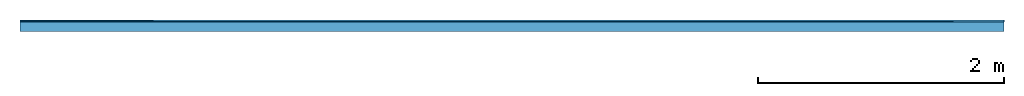
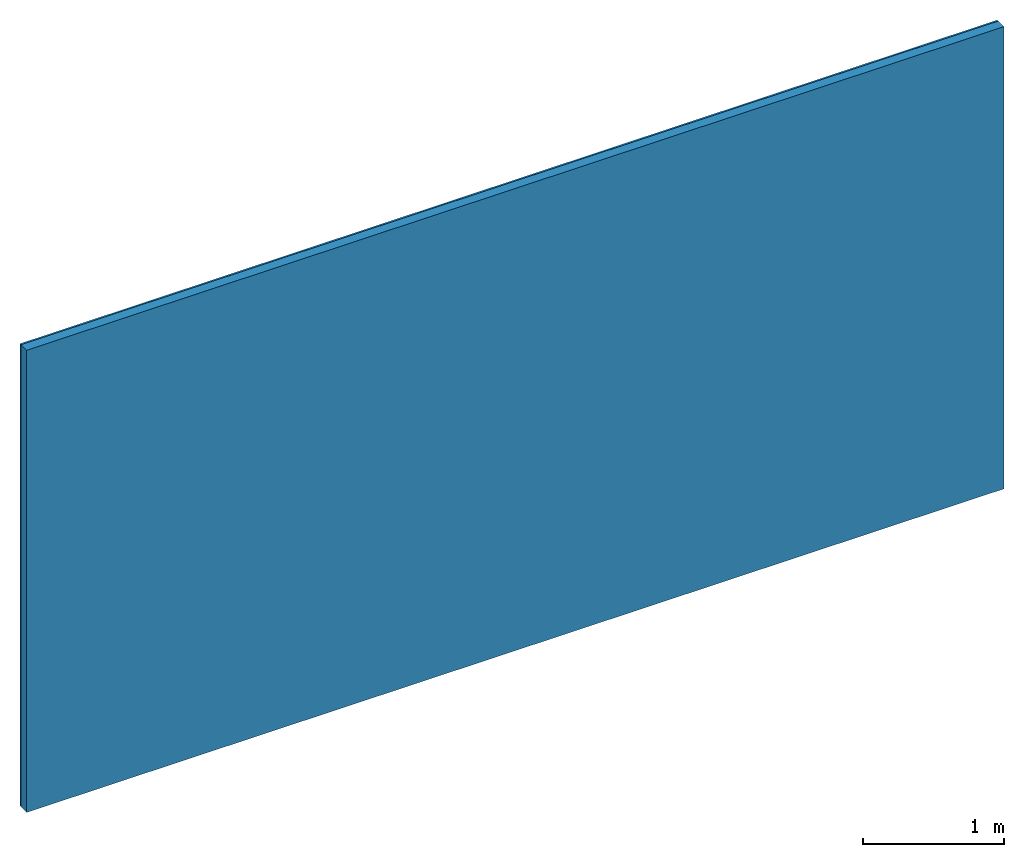
# One storey: 1 member, 1 plate, 1 element without a shape of its own.
"""IFC4 building model written with IfcOpenShell, lengths in metres."""

from ifc_helpers import new_model, si_unit, derived_unit, direction, frame, frame_2d, origin, origin_with_axes, place, context, project, spatial, rectangle, extrude, material, layer, layer_set, type_object, element, aggregate, save


model = new_model("IFC4")

# Units and contexts
plan_context = context("Plan", 3, precision=1e-05, world=origin(), true_north=direction((0.0, 1.0)))
model_context = context("Model", 3, precision=1e-05, world=origin(), true_north=direction((0.0, 1.0)))
ifc_project = project(units=[si_unit("LENGTHUNIT", "METRE"), derived_unit("SOUNDPRESSUREUNIT", [(si_unit("PRESSUREUNIT", "PASCAL", prefix="MICRO"), 0)]), si_unit("ENERGYUNIT", "JOULE", prefix="MEGA"), si_unit("MASSUNIT", "GRAM", prefix="KILO"), derived_unit("THERMALTRANSMITTANCEUNIT", [(si_unit("POWERUNIT", "WATT"), 1), (si_unit("AREAUNIT", "SQUARE_METRE"), -1), (si_unit("THERMODYNAMICTEMPERATUREUNIT", "KELVIN"), -1)]), derived_unit("AREADENSITYUNIT", [(si_unit("MASSUNIT", "GRAM", prefix="KILO"), 1), (si_unit("AREAUNIT", "SQUARE_METRE"), -1)]), derived_unit("USERDEFINED", [(si_unit("ENERGYUNIT", "JOULE", prefix="MEGA"), 1), (si_unit("AREAUNIT", "SQUARE_METRE"), -1)])], contexts=[plan_context, model_context])

# Site, building, storey
site = spatial("IfcSite", under=ifc_project)
building_placement = place(None, origin())
building = spatial("IfcBuilding", under=site, at=building_placement)
storey_placement = place(building_placement, origin())
storey = spatial("IfcBuildingStorey", under=building, at=storey_placement)

# Wall, member, plate
ifc_material_1 = material(Name="Glued joints")
ifc_layer_1 = layer(ifc_material_1, 0.0, Name="Surface")
ifc_material_2 = material(Category="03.007")
ifc_layer_2 = layer(ifc_material_2, 0.015, Name="1st layer")
ifc_material_3 = material(Name="of the art")
ifc_layer_3 = layer(ifc_material_3, 0.0, Name="Bond")
ifc_layer_4 = layer(None, 0.08, Name="Support")
ifc_layer_set = layer_set([ifc_layer_1, ifc_layer_2, ifc_layer_3, ifc_layer_4])
wall_type = type_object("IfcWallType", Name="C0111", PredefinedType="NOTDEFINED", material=ifc_layer_set)
wall_placement = place(None, frame((0.0, 0.0, 0.0), z_axis=(0.0, -1.0, 0.0), x_axis=(1.0, 0.0, 0.0)))
wall = element("IfcWall", 1, at=wall_placement, inside=storey, type_object=wall_type, material=ifc_layer_set, Name="Wall #1")
ifc_material_4 = material()
member_placement = place(wall_placement, origin())
member = element("IfcMember", 2, at=member_placement, material=ifc_material_4, Name="Support", context=plan_context, shape_type="SweptSolid", body=[
    extrude(rectangle(XDim=1.0, YDim=0.08, at=frame_2d((0.5, 0.04), x_axis=(1.0, 0.0))), frame((0.0, 4.0, 0.015), z_axis=(0.0, -1.0, 0.0), x_axis=(1.0, 0.0, 0.0)), (0.0, 0.0, 1.0), 4.0),
    extrude(rectangle(XDim=1.0, YDim=0.08, at=frame_2d((0.5, 0.04), x_axis=(1.0, 0.0))), frame((1.0, 4.0, 0.015), z_axis=(0.0, -1.0, 0.0), x_axis=(1.0, 0.0, 0.0)), (0.0, 0.0, 1.0), 4.0),
    extrude(rectangle(XDim=1.0, YDim=0.08, at=frame_2d((0.5, 0.04), x_axis=(1.0, 0.0))), frame((2.0, 4.0, 0.015), z_axis=(0.0, -1.0, 0.0), x_axis=(1.0, 0.0, 0.0)), (0.0, 0.0, 1.0), 4.0),
    extrude(rectangle(XDim=1.0, YDim=0.08, at=frame_2d((0.5, 0.04), x_axis=(1.0, 0.0))), frame((3.0, 4.0, 0.015), z_axis=(0.0, -1.0, 0.0), x_axis=(1.0, 0.0, 0.0)), (0.0, 0.0, 1.0), 4.0),
    extrude(rectangle(XDim=1.0, YDim=0.08, at=frame_2d((0.5, 0.04), x_axis=(1.0, 0.0))), frame((4.0, 4.0, 0.015), z_axis=(0.0, -1.0, 0.0), x_axis=(1.0, 0.0, 0.0)), (0.0, 0.0, 1.0), 4.0),
    extrude(rectangle(XDim=1.0, YDim=0.08, at=frame_2d((0.5, 0.04), x_axis=(1.0, 0.0))), frame((5.0, 4.0, 0.015), z_axis=(0.0, -1.0, 0.0), x_axis=(1.0, 0.0, 0.0)), (0.0, 0.0, 1.0), 4.0),
    extrude(rectangle(XDim=1.0, YDim=0.08, at=frame_2d((0.5, 0.04), x_axis=(1.0, 0.0))), frame((6.0, 4.0, 0.015), z_axis=(0.0, -1.0, 0.0), x_axis=(1.0, 0.0, 0.0)), (0.0, 0.0, 1.0), 4.0),
    extrude(rectangle(XDim=1.0, YDim=0.08, at=frame_2d((0.5, 0.04), x_axis=(1.0, 0.0))), frame((7.0, 4.0, 0.015), z_axis=(0.0, -1.0, 0.0), x_axis=(1.0, 0.0, 0.0)), (0.0, 0.0, 1.0), 4.0),
])
plate_placement = place(wall_placement, origin())
plate = element("IfcPlate", 3, at=plate_placement, material=ifc_material_2, Name="1st layer", context=plan_context, shape_type="SweptSolid", body=[
    extrude(rectangle(XDim=8.0, YDim=4.0, at=frame_2d((4.0, 2.0), x_axis=(1.0, 0.0))), origin_with_axes(), (0.0, 0.0, 1.0), 0.015),
])
aggregate(wall, [plate, member])

save(model, "model.ifc")
